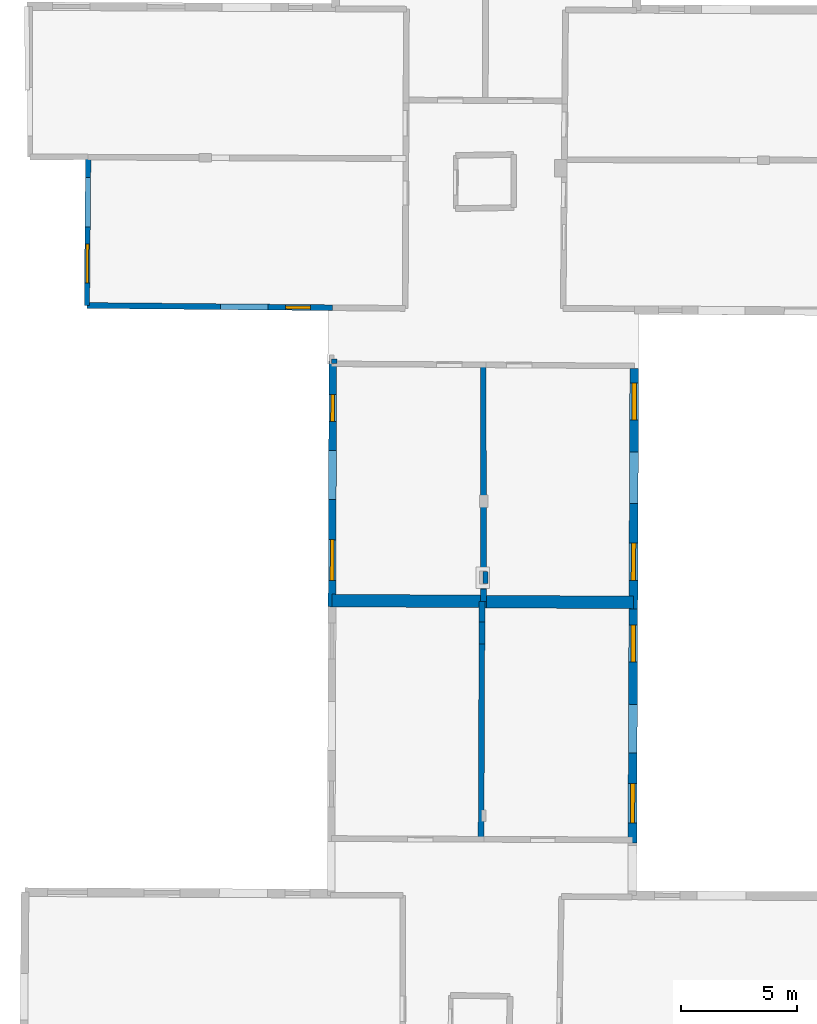
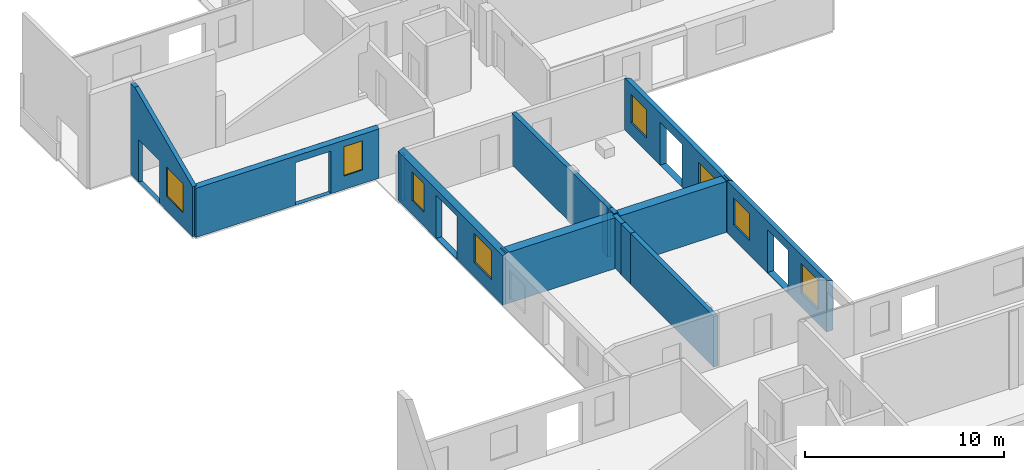
# One storey, part 5 of 10: 14 walls, 8 windows, 13 openings.
"""IFC2X3 building model written with IfcOpenShell, lengths in metres."""

from ifc_helpers import new_model, entity, si_unit, converted_unit, derived_unit, direction, frame, frame_2d, origin, origin_2d_with_axis, place, context, subcontext, project, spatial, polyline, rectangle, outline, extrude, clip, halfspace, source, transform, mapped, material, layer, layer_set, layer_usage, type_object, type_shapes, element, fill, save


model = new_model("IFC2X3")

# Units and contexts
model_context = context("Model", 3, precision=1e-05, world=origin(), true_north=direction((0.0, 1.0)))
body_context = subcontext(model_context, "Body", "Model", "MODEL_VIEW")
ifc_project = project(units=[si_unit("LENGTHUNIT", "METRE"), si_unit("AREAUNIT", "SQUARE_METRE"), si_unit("VOLUMEUNIT", "CUBIC_METRE"), converted_unit("PLANEANGLEUNIT", "DEGREE", entity("IfcRatioMeasure", 0.0174532925199433), si_unit("PLANEANGLEUNIT", "RADIAN"), dimensions=[0, 0, 0, 0, 0, 0, 0]), si_unit("MASSUNIT", "GRAM", prefix="KILO"), derived_unit("MASSDENSITYUNIT", [(si_unit("MASSUNIT", "GRAM", prefix="KILO"), 1), (si_unit("LENGTHUNIT", "METRE"), -3)]), derived_unit("MOMENTOFINERTIAUNIT", [(si_unit("LENGTHUNIT", "METRE"), 4)]), si_unit("TIMEUNIT", "SECOND"), si_unit("FREQUENCYUNIT", "HERTZ"), si_unit("THERMODYNAMICTEMPERATUREUNIT", "DEGREE_CELSIUS"), derived_unit("THERMALTRANSMITTANCEUNIT", [(si_unit("MASSUNIT", "GRAM", prefix="KILO"), 1), (si_unit("THERMODYNAMICTEMPERATUREUNIT", "KELVIN"), -1), (si_unit("TIMEUNIT", "SECOND"), -3)]), derived_unit("VOLUMETRICFLOWRATEUNIT", [(si_unit("LENGTHUNIT", "METRE"), 3), (si_unit("TIMEUNIT", "SECOND"), -1)]), si_unit("ELECTRICCURRENTUNIT", "AMPERE"), si_unit("ELECTRICVOLTAGEUNIT", "VOLT"), si_unit("POWERUNIT", "WATT"), si_unit("FORCEUNIT", "NEWTON", prefix="KILO"), si_unit("ILLUMINANCEUNIT", "LUX"), si_unit("LUMINOUSFLUXUNIT", "LUMEN"), si_unit("LUMINOUSINTENSITYUNIT", "CANDELA"), derived_unit("USERDEFINED", [(si_unit("MASSUNIT", "GRAM", prefix="KILO"), -1), (si_unit("LENGTHUNIT", "METRE"), -2), (si_unit("TIMEUNIT", "SECOND"), 3), (si_unit("LUMINOUSFLUXUNIT", "LUMEN"), 1)]), derived_unit("LINEARVELOCITYUNIT", [(si_unit("LENGTHUNIT", "METRE"), 1), (si_unit("TIMEUNIT", "SECOND"), -1)]), si_unit("PRESSUREUNIT", "PASCAL"), derived_unit("USERDEFINED", [(si_unit("LENGTHUNIT", "METRE"), -2), (si_unit("MASSUNIT", "GRAM", prefix="KILO"), 1), (si_unit("TIMEUNIT", "SECOND"), -2)]), derived_unit("LINEARFORCEUNIT", [(si_unit("MASSUNIT", "GRAM", prefix="KILO"), 1), (si_unit("LENGTHUNIT", "METRE"), 1), (si_unit("TIMEUNIT", "SECOND"), -2), (si_unit("LENGTHUNIT", "METRE"), -1)]), derived_unit("PLANARFORCEUNIT", [(si_unit("MASSUNIT", "GRAM", prefix="KILO"), 1), (si_unit("LENGTHUNIT", "METRE"), 1), (si_unit("TIMEUNIT", "SECOND"), -2), (si_unit("LENGTHUNIT", "METRE"), -2)])], contexts=[model_context])

# Site, building, storey
placement = place(None, origin())
site = spatial("IfcSite", under=ifc_project, at=placement, CompositionType="ELEMENT")
building = spatial("IfcBuilding", under=site, at=placement, CompositionType="ELEMENT")
storey_placement = place(placement, frame((0.0, 0.0, 15.2695512771606)))
storey = spatial("IfcBuildingStorey", under=building, at=storey_placement, Name="Level 6", CompositionType="ELEMENT", Elevation=15.2695512771606)

# Wall, openings, window
ifc_material_1 = material(Name="Default wall")
ifc_layer_1 = layer(ifc_material_1, 0.25)
ifc_layer_set_1 = layer_set([ifc_layer_1], Name="wall_thickness_0.2500")
ifc_layer_usage_1 = layer_usage(ifc_layer_set_1, "AXIS2", "POSITIVE", -0.125)
wall_type_1 = type_object("IfcWallType", Name="wall_thickness_0.2500", PredefinedType="STANDARD", material=ifc_layer_set_1)
wall_1_placement = place(storey_placement, frame((-10.7918631542539, 51.3182891872062, 0.0), z_axis=(0.0, 0.0, 1.0), x_axis=(0.999957297563453, -0.00924137704003364, 0.0)))
wall_1 = element("IfcWallStandardCase", 1, at=wall_1_placement, inside=storey, type_object=wall_type_1, material=ifc_layer_usage_1, Name="Wall:131", ObjectType="Wall", context=body_context, shape_type="Clipping", body=[
    clip(extrude(outline(polyline([(10.5928760190605, -0.125), (10.5928760190605, 0.125), (0.0, 0.125), (0.0, -0.125), (10.5928760190605, -0.125)])), origin(), (0.0, 0.0, 1.0), 3.13044834136963), halfspace(frame((-2.02118983756766, 6.47053663149415, 5.82614615592769), z_axis=(-0.000273451159265104, -0.391129659619298, 0.920335544565435), x_axis=(0.999999114826183, 0.00109145221918171, 0.000760972341273259)), False)),
])
opening_1_placement = place(wall_1_placement, frame((5.74937331769566, -0.125, 0.00544929504394531)))
element("IfcOpeningElement", 2, at=opening_1_placement, cuts=wall_1, Name="Opening : 2065 x 2610 : 121", ObjectType="Opening", context=body_context, shape_type="SweptSolid", body=[
    extrude(rectangle(XDim=2.065, YDim=2.61, at=frame_2d((1.305, 1.0325), x_axis=(0.0, 1.0))), frame((0.0, 0.0, 0.0), z_axis=(0.0, 1.0, 0.0), x_axis=(0.0, 0.0, 1.0)), (0.0, 0.0, 1.0), 0.25),
])
opening_2_placement = place(wall_1_placement, frame((8.56937256748075, -0.125, 0.835448265075684)))
opening_2 = element("IfcOpeningElement", 3, at=opening_2_placement, cuts=wall_1, Name="Opening : 1075 x 1795 : 122", ObjectType="Opening", context=body_context, shape_type="SweptSolid", body=[
    extrude(rectangle(XDim=1.075, YDim=1.795, at=frame_2d((0.8975, 0.5375), x_axis=(0.0, 1.0))), frame((0.0, 0.0, 0.0), z_axis=(0.0, 1.0, 0.0), x_axis=(0.0, 0.0, 1.0)), (0.0, 0.0, 1.0), 0.25),
])
ifc_material_2 = material(Name="Window Default")
window_style_1 = type_object("IfcWindowStyle", Name="Window : 1075 x 1795mm", ConstructionType="NOTDEFINED", OperationType="NOTDEFINED", ParameterTakesPrecedence=False, Sizeable=False, material=ifc_material_2)
shared_shape_1 = source(origin(), body_context, "Body", "SweptSolid", [
    extrude(rectangle(XDim=0.125, YDim=1.075, at=origin_2d_with_axis()), frame((0.5375, 0.125, 0.0), z_axis=(0.0, 0.0, 1.0), x_axis=(0.0, 1.0, 0.0)), (0.0, 0.0, 1.0), 1.795),
])
type_shapes(window_style_1, [shared_shape_1])
window_1_placement = place(opening_2_placement, origin())
window_1 = element("IfcWindow", 4, at=window_1_placement, inside=storey, type_object=window_style_1, Name="Window : 1075 x 1795mm : 69", ObjectType="Window : 1075 x 1795mm", OverallHeight=1.795, OverallWidth=1.075, context=body_context, shape_type="MappedRepresentation", body=[
    mapped(shared_shape_1, transform((0.0, 0.0, 0.0), scale=1.0)),
])
fill(opening_2, window_1)

# Walls
wall_2_placement = place(storey_placement, frame((6.31263852791467, 38.554241578399, 0.0), z_axis=(0.0, 0.0, 1.0), x_axis=(-0.00198018533380732, 0.9999980394311, 0.0)))
element("IfcWallStandardCase", 5, at=wall_2_placement, inside=storey, type_object=wall_type_1, material=ifc_layer_usage_1, Name="Wall:135", ObjectType="Wall", context=body_context, shape_type="Clipping", body=[
    clip(extrude(outline(polyline([(0.536271192998185, -0.125), (0.536271192998185, 0.125), (0.0, 0.125), (0.0, -0.125), (0.536271192998185, -0.125)])), origin(), (0.0, 0.0, 1.0), 3.19044971466064), halfspace(frame((38.6694217245031, -6.58047150093401, 3.16730048752112), z_axis=(-0.00267704851674191, -0.390490946460166, 0.920602875372374), x_axis=(-0.668902738376061, 0.685029747602451, 0.288623234499112)), False)),
])
wall_3_placement = place(storey_placement, frame((6.31157661156335, 39.0905117200006, 0.0), z_axis=(0.0, 0.0, 1.0), x_axis=(-0.00198054367142939, 0.999998038721459, 0.0)))
element("IfcWallStandardCase", 6, at=wall_3_placement, inside=storey, type_object=wall_type_1, material=ifc_layer_usage_1, Name="Wall:136", ObjectType="Wall", context=body_context, shape_type="Clipping", body=[
    clip(extrude(outline(polyline([(9.66558063292127, -0.125), (9.66558063292127, 0.125), (0.0, 0.125), (0.0, -0.125), (9.66558063292127, -0.125)])), origin(), (0.0, 0.0, 1.0), 3.19044971466064), halfspace(frame((38.1331481734673, -6.58048516550286, 3.16730048752112), z_axis=(-0.00267718844461334, -0.390490945500852, 0.920602875372374), x_axis=(-0.668902492903606, 0.685029987295894, 0.288623234499112)), False)),
])
wall_4_placement = place(storey_placement, frame((6.24366578217228, 38.5547016510768, 0.0), z_axis=(0.0, 0.0, 1.0), x_axis=(-0.00408089298600891, -0.99999167312155, 0.0)))
element("IfcWallStandardCase", 7, at=wall_4_placement, inside=storey, type_object=wall_type_1, material=ifc_layer_usage_1, Name="Wall:151", ObjectType="Wall", context=body_context, shape_type="Clipping", body=[
    clip(extrude(outline(polyline([(0.877048166110583, -0.125), (0.877048166110583, 0.125), (0.0, 0.125), (0.0, -0.125), (0.877048166110583, -0.125)])), origin(), (0.0, 0.0, 1.0), 3.13044834136963), halfspace(frame((-37.2581581659903, -7.65857692326388, 2.60439273833051), z_axis=(0.000176715012674681, -0.389900733728327, 0.920856876289642), x_axis=(0.00178910517912589, 0.920854275964437, 0.389902810378011)), False)),
])
wall_5_placement = place(storey_placement, frame((6.24008664246281, 37.6776607880397, 0.0), z_axis=(0.0, 0.0, 1.0), x_axis=(-0.00408033523561015, -0.999991675397533, 0.0)))
element("IfcWallStandardCase", 8, at=wall_5_placement, inside=storey, type_object=wall_type_1, material=ifc_layer_usage_1, Name="Wall:152", ObjectType="Wall", context=body_context, shape_type="Clipping", body=[
    clip(extrude(outline(polyline([(0.965866499927304, -0.125), (0.965866499927304, 0.125), (0.0, 0.125), (0.0, -0.125), (0.965866499927304, -0.125)])), origin(), (0.0, 0.0, 1.0), 3.13044834136963), halfspace(frame((-38.1352106037049, -7.65855565315906, 2.60439273833051), z_axis=(0.000176497543574304, -0.38990073382683, 0.920856876289642), x_axis=(0.00178961879024267, 0.920854274966411, 0.38990281037801)), False)),
])
wall_6_placement = place(storey_placement, frame((6.23614558335026, 36.711802328567, 0.0), z_axis=(0.0, 0.0, 1.0), x_axis=(-0.00408045797511642, -0.999991674896703, 0.0)))
element("IfcWallStandardCase", 9, at=wall_6_placement, inside=storey, type_object=wall_type_1, material=ifc_layer_usage_1, Name="Wall:153", ObjectType="Wall", context=body_context, shape_type="Clipping", body=[
    clip(extrude(outline(polyline([(8.40821971853598, -0.125), (8.40821971853598, 0.125), (0.0, 0.125), (0.0, -0.125), (8.40821971853598, -0.125)])), origin(), (0.0, 0.0, 1.0), 3.13044834136963), halfspace(frame((-39.1010761636167, -7.65856045244585, 2.60439273833051), z_axis=(0.000176545400196313, -0.389900733805164, 0.920856876289642), x_axis=(0.00178950576410035, 0.920854275186063, 0.389902810378011)), False)),
])

# Wall, openings, windows
ifc_layer_2 = layer(ifc_material_1, 0.330000013113022)
ifc_layer_set_2 = layer_set([ifc_layer_2], Name="wall_thickness_0.3300")
ifc_layer_usage_2 = layer_usage(ifc_layer_set_2, "AXIS2", "POSITIVE", -0.165000006556511)
wall_type_2 = type_object("IfcWallType", Name="wall_thickness_0.3300", PredefinedType="STANDARD", material=ifc_layer_set_2)
wall_7_placement = place(storey_placement, frame((-0.189888935039893, 48.9134317004756, 0.0), z_axis=(0.0, 0.0, 1.0), x_axis=(-0.00325150151476131, -0.999994713854978, 0.0)))
wall_7 = element("IfcWallStandardCase", 10, at=wall_7_placement, inside=storey, type_object=wall_type_2, material=ifc_layer_usage_2, Name="Wall:182", ObjectType="Wall", context=body_context, shape_type="Clipping", body=[
    clip(extrude(outline(polyline([(10.5857187994416, -0.165000006556511), (10.5857187994416, 0.165000006556511), (0.0, 0.165000006556511), (0.0, -0.165000006556511), (10.5857187994416, -0.165000006556511)])), origin(), (0.0, 0.0, 1.0), 3.19044971466064), halfspace(frame((-26.9267407728403, -1.1604703505064, 2.60439273833051), z_axis=(-0.000146667536787267, -0.389900746188972, 0.920856876289642), x_axis=(0.00255285831366355, 0.920852475358436, 0.389902810378011)), False)),
])
opening_3_placement = place(wall_7_placement, frame((3.8414395264122, -0.165000006556511, 0.00544929504394531)))
element("IfcOpeningElement", 11, at=opening_3_placement, cuts=wall_7, Name="Opening : 2130 x 2655 : 159", ObjectType="Opening", context=body_context, shape_type="SweptSolid", body=[
    extrude(rectangle(XDim=2.13, YDim=2.655, at=frame_2d((1.3275, 1.065), x_axis=(0.0, 1.0))), frame((0.0, 0.0, 0.0), z_axis=(0.0, 1.0, 0.0), x_axis=(0.0, 0.0, 1.0)), (0.0, 0.0, 1.0), 0.330000013113022),
])
opening_4_placement = place(wall_7_placement, frame((7.69643655852711, -0.165000006556511, 0.870450019836426)))
opening_4 = element("IfcOpeningElement", 12, at=opening_4_placement, cuts=wall_7, Name="Opening : 1750 x 1775 : 160", ObjectType="Opening", context=body_context, shape_type="SweptSolid", body=[
    extrude(rectangle(XDim=1.75, YDim=1.775, at=frame_2d((0.8875, 0.875), x_axis=(0.0, 1.0))), frame((0.0, 0.0, 0.0), z_axis=(0.0, 1.0, 0.0), x_axis=(0.0, 0.0, 1.0)), (0.0, 0.0, 1.0), 0.330000013113022),
])
opening_5_placement = place(wall_7_placement, frame((1.42644491834091, -0.165000006556511, 0.86044979095459)))
opening_5 = element("IfcOpeningElement", 13, at=opening_5_placement, cuts=wall_7, Name="Opening : 1170 x 1770 : 161", ObjectType="Opening", context=body_context, shape_type="SweptSolid", body=[
    extrude(rectangle(XDim=1.17, YDim=1.77, at=frame_2d((0.885, 0.585), x_axis=(0.0, 1.0))), frame((0.0, 0.0, 0.0), z_axis=(0.0, 1.0, 0.0), x_axis=(0.0, 0.0, 1.0)), (0.0, 0.0, 1.0), 0.330000013113022),
])
window_style_2 = type_object("IfcWindowStyle", Name="Window : 1750 x 1775mm", ConstructionType="NOTDEFINED", OperationType="NOTDEFINED", ParameterTakesPrecedence=False, Sizeable=False, material=ifc_material_2)
shared_shape_2 = source(origin(), body_context, "Body", "SweptSolid", [
    extrude(rectangle(XDim=0.165000006556511, YDim=1.75, at=origin_2d_with_axis()), frame((0.875, 0.165000006556511, 0.0), z_axis=(0.0, 0.0, 1.0), x_axis=(0.0, 1.0, 0.0)), (0.0, 0.0, 1.0), 1.775),
])
type_shapes(window_style_2, [shared_shape_2])
window_2_placement = place(opening_4_placement, origin())
window_2 = element("IfcWindow", 14, at=window_2_placement, inside=storey, type_object=window_style_2, Name="Window : 1750 x 1775mm : 87", ObjectType="Window : 1750 x 1775mm", OverallHeight=1.775, OverallWidth=1.75, context=body_context, shape_type="MappedRepresentation", body=[
    mapped(shared_shape_2, transform((0.0, 0.0, 0.0), scale=1.0)),
])
fill(opening_4, window_2)
window_style_3 = type_object("IfcWindowStyle", Name="Window : 1170 x 1770mm", ConstructionType="NOTDEFINED", OperationType="NOTDEFINED", ParameterTakesPrecedence=False, Sizeable=False, material=ifc_material_2)
shared_shape_3 = source(origin(), body_context, "Body", "SweptSolid", [
    extrude(rectangle(XDim=0.165000006556511, YDim=1.17, at=origin_2d_with_axis()), frame((0.585, 0.165000006556511, 0.0), z_axis=(0.0, 0.0, 1.0), x_axis=(0.0, 1.0, 0.0)), (0.0, 0.0, 1.0), 1.77),
])
type_shapes(window_style_3, [shared_shape_3])
window_3_placement = place(opening_5_placement, origin())
window_3 = element("IfcWindow", 15, at=window_3_placement, inside=storey, type_object=window_style_3, Name="Window : 1170 x 1770mm : 88", ObjectType="Window : 1170 x 1770mm", OverallHeight=1.77, OverallWidth=1.17, context=body_context, shape_type="MappedRepresentation", body=[
    mapped(shared_shape_3, transform((0.0, 0.0, 0.0), scale=1.0)),
])
fill(opening_5, window_3)

# Walls
ifc_layer_3 = layer(ifc_material_1, 0.2)
ifc_layer_set_3 = layer_set([ifc_layer_3], Name="wall_thickness_0.2000")
ifc_layer_usage_3 = layer_usage(ifc_layer_set_3, "AXIS2", "POSITIVE", -0.1)
wall_type_3 = type_object("IfcWallType", Name="wall_thickness_0.2000", PredefinedType="STANDARD", material=ifc_layer_set_3)
wall_8_placement = place(storey_placement, frame((-0.239136508430576, 48.9138898782776, 0.0), z_axis=(0.0, 0.0, 1.0), x_axis=(0.999956321638028, -0.00934637984166514, 0.0)))
element("IfcWallStandardCase", 16, at=wall_8_placement, inside=storey, type_object=wall_type_3, material=ifc_layer_usage_3, Name="Wall:159", ObjectType="Wall", context=body_context, shape_type="Clipping", body=[
    clip(extrude(outline(polyline([(0.234684547909792, -0.1), (0.234684547909792, 0.1), (0.0, 0.1), (0.0, -0.1), (0.234684547909792, -0.1)])), origin(), (0.0, 0.0, 1.0), 2.80144786834717), halfspace(frame((-1.27531679324172, 26.9191697175549, 2.60439273833051), z_axis=(-0.38989439790886, -0.00222976890532546, 0.920856876289642), x_axis=(0.920850930574104, 0.00305975818253765, 0.389902810378011)), False)),
])
wall_9_placement = place(storey_placement, frame((6.38936056579438, 39.8542914346706, 0.0), z_axis=(0.0, 0.0, 1.0), x_axis=(0.00216104203392475, -0.999997664945938, 0.0)))
element("IfcWallStandardCase", 17, at=wall_9_placement, inside=storey, type_object=wall_type_3, material=ifc_layer_usage_3, Name="Wall:203", ObjectType="Wall", context=body_context, shape_type="Clipping", body=[
    clip(extrude(outline(polyline([(0.515000592202662, -0.1), (0.515000592202662, 0.1), (0.0, 0.1), (0.0, -0.1), (0.515000592202662, -0.1)])), origin(), (0.0, 0.0, 1.0), 3.13044834136963), halfspace(frame((-37.3683499461351, 6.50793371116991, 3.16730048752112), z_axis=(0.00274767152806975, 0.390490455910629, 0.920602875372374), x_axis=(0.668778834951677, -0.68515071219984, 0.288623234499112)), False)),
])

# Wall, openings, windows
ifc_layer_4 = layer(ifc_material_1, 0.379999995231628)
ifc_layer_set_4 = layer_set([ifc_layer_4], Name="wall_thickness_0.3800")
ifc_layer_usage_4 = layer_usage(ifc_layer_set_4, "AXIS2", "POSITIVE", -0.189999997615814)
wall_type_4 = type_object("IfcWallType", Name="wall_thickness_0.3800", PredefinedType="STANDARD", material=ifc_layer_set_4)
wall_10_placement = place(storey_placement, frame((12.8059081019652, 48.5902860163379, 0.0), z_axis=(0.0, 0.0, 1.0), x_axis=(-0.00393639471888674, -0.999992252368296, 0.0)))
wall_10 = element("IfcWallStandardCase", 18, at=wall_10_placement, inside=storey, type_object=wall_type_4, material=ifc_layer_usage_4, Name="Wall:141", ObjectType="Wall", context=body_context, shape_type="Clipping", body=[
    clip(extrude(outline(polyline([(10.3490906484721, -0.189999997615814), (10.3490906484721, 0.189999997615814), (0.0, 0.189999997615814), (0.0, -0.189999997615814), (10.3490906484721, -0.189999997615814)])), origin(), (0.0, 0.0, 1.0), 3.19044971466064), halfspace(frame((-28.6461518747793, -0.10214694870322, 3.16730048752112), z_axis=(0.000366639720296356, 0.390499950616428, 0.920602875372374), x_axis=(0.672944048130993, -0.681060156368248, 0.288623234499112)), False)),
])
opening_6_placement = place(wall_10_placement, frame((3.58036907290505, -0.189999997615814, 0.00544929504394531)))
element("IfcOpeningElement", 19, at=opening_6_placement, cuts=wall_10, Name="Opening : 2235 x 2655 : 129", ObjectType="Opening", context=body_context, shape_type="SweptSolid", body=[
    extrude(rectangle(XDim=2.235, YDim=2.655, at=frame_2d((1.3275, 1.1175), x_axis=(0.0, 1.0))), frame((0.0, 0.0, 0.0), z_axis=(0.0, 1.0, 0.0), x_axis=(0.0, 0.0, 1.0)), (0.0, 0.0, 1.0), 0.379999995231628),
])
opening_7_placement = place(wall_10_placement, frame((7.50497909873924, -0.189999997615814, 0.850449562072754)))
opening_7 = element("IfcOpeningElement", 20, at=opening_7_placement, cuts=wall_10, Name="Opening : 1630 x 1710 : 130", ObjectType="Opening", context=body_context, shape_type="SweptSolid", body=[
    extrude(rectangle(XDim=1.63, YDim=1.71, at=frame_2d((0.855, 0.815), x_axis=(0.0, 1.0))), frame((0.0, 0.0, 0.0), z_axis=(0.0, 1.0, 0.0), x_axis=(0.0, 0.0, 1.0)), (0.0, 0.0, 1.0), 0.379999995231628),
])
opening_8_placement = place(wall_10_placement, frame((0.624981947167531, -0.189999997615814, 0.835448265075684)))
opening_8 = element("IfcOpeningElement", 21, at=opening_8_placement, cuts=wall_10, Name="Opening : 1595 x 1745 : 131", ObjectType="Opening", context=body_context, shape_type="SweptSolid", body=[
    extrude(rectangle(XDim=1.595, YDim=1.745, at=frame_2d((0.8725, 0.7975), x_axis=(0.0, 1.0))), frame((0.0, 0.0, 0.0), z_axis=(0.0, 1.0, 0.0), x_axis=(0.0, 0.0, 1.0)), (0.0, 0.0, 1.0), 0.379999995231628),
])
window_style_4 = type_object("IfcWindowStyle", Name="Window : 1630 x 1710mm", ConstructionType="NOTDEFINED", OperationType="NOTDEFINED", ParameterTakesPrecedence=False, Sizeable=False, material=ifc_material_2)
shared_shape_4 = source(origin(), body_context, "Body", "SweptSolid", [
    extrude(rectangle(XDim=0.189999997615814, YDim=1.63, at=origin_2d_with_axis()), frame((0.815, 0.189999997615814, 0.0), z_axis=(0.0, 0.0, 1.0), x_axis=(0.0, 1.0, 0.0)), (0.0, 0.0, 1.0), 1.71),
])
type_shapes(window_style_4, [shared_shape_4])
window_4_placement = place(opening_7_placement, origin())
window_4 = element("IfcWindow", 22, at=window_4_placement, inside=storey, type_object=window_style_4, Name="Window : 1630 x 1710mm : 74", ObjectType="Window : 1630 x 1710mm", OverallHeight=1.71, OverallWidth=1.63, context=body_context, shape_type="MappedRepresentation", body=[
    mapped(shared_shape_4, transform((0.0, 0.0, 0.0), scale=1.0)),
])
fill(opening_7, window_4)
window_style_5 = type_object("IfcWindowStyle", Name="Window : 1595 x 1745mm", ConstructionType="NOTDEFINED", OperationType="NOTDEFINED", ParameterTakesPrecedence=False, Sizeable=False, material=ifc_material_2)
shared_shape_5 = source(origin(), body_context, "Body", "SweptSolid", [
    extrude(rectangle(XDim=0.189999997615814, YDim=1.595, at=origin_2d_with_axis()), frame((0.7975, 0.189999997615814, 0.0), z_axis=(0.0, 0.0, 1.0), x_axis=(0.0, 1.0, 0.0)), (0.0, 0.0, 1.0), 1.745),
])
type_shapes(window_style_5, [shared_shape_5])
window_5_placement = place(opening_8_placement, origin())
window_5 = element("IfcWindow", 23, at=window_5_placement, inside=storey, type_object=window_style_5, Name="Window : 1595 x 1745mm : 75", ObjectType="Window : 1595 x 1745mm", OverallHeight=1.745, OverallWidth=1.595, context=body_context, shape_type="MappedRepresentation", body=[
    mapped(shared_shape_5, transform((0.0, 0.0, 0.0), scale=1.0)),
])
fill(opening_8, window_5)

wall_11_placement = place(storey_placement, frame((12.7651699961913, 38.2412755488086, 0.0), z_axis=(0.0, 0.0, 1.0), x_axis=(-0.00393640518905978, -0.999992252327081, 0.0)))
wall_11 = element("IfcWallStandardCase", 24, at=wall_11_placement, inside=storey, type_object=wall_type_4, material=ifc_layer_usage_4, Name="Wall:142", ObjectType="Wall", context=body_context, shape_type="Clipping", body=[
    clip(extrude(outline(polyline([(10.0922565362292, -0.189999997615814), (10.0922565362292, 0.189999997615814), (0.0, 0.189999997615814), (0.0, -0.189999997615814), (10.0922565362292, -0.189999997615814)])), origin(), (0.0, 0.0, 1.0), 3.19044971466064), halfspace(frame((-38.9952425221819, -0.102147356993322, 3.16730048752112), z_axis=(0.000366635631662601, 0.390499950620267, 0.920602875372374), x_axis=(0.672944055261866, -0.681060149322352, 0.288623234499112)), False)),
])
opening_9_placement = place(wall_11_placement, frame((4.11753983128788, -0.189999997615814, 0.0244483947753906)))
element("IfcOpeningElement", 25, at=opening_9_placement, cuts=wall_11, Name="Opening : 2095 x 2650 : 132", ObjectType="Opening", context=body_context, shape_type="SweptSolid", body=[
    extrude(rectangle(XDim=2.095, YDim=2.65, at=frame_2d((1.325, 1.0475), x_axis=(0.0, 1.0))), frame((0.0, 0.0, 0.0), z_axis=(0.0, 1.0, 0.0), x_axis=(0.0, 0.0, 1.0)), (0.0, 0.0, 1.0), 0.379999995231628),
])
opening_10_placement = place(wall_11_placement, frame((0.690888984294078, -0.189999997615814, 0.865448951721191)))
opening_10 = element("IfcOpeningElement", 26, at=opening_10_placement, cuts=wall_11, Name="Opening : 1595 x 1680 : 133", ObjectType="Opening", context=body_context, shape_type="SweptSolid", body=[
    extrude(rectangle(XDim=1.595, YDim=1.68, at=frame_2d((0.84, 0.7975), x_axis=(0.0, 1.0))), frame((0.0, 0.0, 0.0), z_axis=(0.0, 1.0, 0.0), x_axis=(0.0, 0.0, 1.0)), (0.0, 0.0, 1.0), 0.379999995231628),
])
opening_11_placement = place(wall_11_placement, frame((7.52754130578347, -0.189999997615814, 0.869448661804199)))
opening_11 = element("IfcOpeningElement", 27, at=opening_11_placement, cuts=wall_11, Name="Opening : 1700 x 1805 : 134", ObjectType="Opening", context=body_context, shape_type="SweptSolid", body=[
    extrude(rectangle(XDim=1.7, YDim=1.805, at=frame_2d((0.9025, 0.85), x_axis=(0.0, 1.0))), frame((0.0, 0.0, 0.0), z_axis=(0.0, 1.0, 0.0), x_axis=(0.0, 0.0, 1.0)), (0.0, 0.0, 1.0), 0.379999995231628),
])
window_style_6 = type_object("IfcWindowStyle", Name="Window : 1595 x 1680mm", ConstructionType="NOTDEFINED", OperationType="NOTDEFINED", ParameterTakesPrecedence=False, Sizeable=False, material=ifc_material_2)
shared_shape_6 = source(origin(), body_context, "Body", "SweptSolid", [
    extrude(rectangle(XDim=0.189999997615814, YDim=1.595, at=origin_2d_with_axis()), frame((0.7975, 0.189999997615814, 0.0), z_axis=(0.0, 0.0, 1.0), x_axis=(0.0, 1.0, 0.0)), (0.0, 0.0, 1.0), 1.68),
])
type_shapes(window_style_6, [shared_shape_6])
window_6_placement = place(opening_10_placement, origin())
window_6 = element("IfcWindow", 28, at=window_6_placement, inside=storey, type_object=window_style_6, Name="Window : 1595 x 1680mm : 76", ObjectType="Window : 1595 x 1680mm", OverallHeight=1.68, OverallWidth=1.595, context=body_context, shape_type="MappedRepresentation", body=[
    mapped(shared_shape_6, transform((0.0, 0.0, 0.0), scale=1.0)),
])
fill(opening_10, window_6)
window_style_7 = type_object("IfcWindowStyle", Name="Window : 1700 x 1805mm", ConstructionType="NOTDEFINED", OperationType="NOTDEFINED", ParameterTakesPrecedence=False, Sizeable=False, material=ifc_material_2)
shared_shape_7 = source(origin(), body_context, "Body", "SweptSolid", [
    extrude(rectangle(XDim=0.189999997615814, YDim=1.7, at=origin_2d_with_axis()), frame((0.85, 0.189999997615814, 0.0), z_axis=(0.0, 0.0, 1.0), x_axis=(0.0, 1.0, 0.0)), (0.0, 0.0, 1.0), 1.805),
])
type_shapes(window_style_7, [shared_shape_7])
window_7_placement = place(opening_11_placement, origin())
window_7 = element("IfcWindow", 29, at=window_7_placement, inside=storey, type_object=window_style_7, Name="Window : 1700 x 1805mm : 77", ObjectType="Window : 1700 x 1805mm", OverallHeight=1.805, OverallWidth=1.7, context=body_context, shape_type="MappedRepresentation", body=[
    mapped(shared_shape_7, transform((0.0, 0.0, 0.0), scale=1.0)),
])
fill(opening_11, window_7)

# Walls
ifc_layer_5 = layer(ifc_material_1, 0.540000021457672)
ifc_layer_set_5 = layer_set([ifc_layer_5], Name="wall_thickness_0.5400")
ifc_layer_usage_5 = layer_usage(ifc_layer_set_5, "AXIS2", "POSITIVE", -0.270000010728836)
wall_type_5 = type_object("IfcWallType", Name="wall_thickness_0.5400", PredefinedType="STANDARD", material=ifc_layer_set_5)
wall_12_placement = place(storey_placement, frame((-0.223431040906847, 38.59776044414, 0.0), z_axis=(0.0, 0.0, 1.0), x_axis=(0.999977835940196, -0.00665789969599149, 0.0)))
element("IfcWallStandardCase", 30, at=wall_12_placement, inside=storey, type_object=wall_type_5, material=ifc_layer_usage_5, Name="Wall:169", ObjectType="Wall", context=body_context, shape_type="Clipping", body=[
    clip(extrude(outline(polyline([(6.66121035690246, -0.270000010728836), (6.66121035690246, 0.270000010728836), (0.0, 0.270000010728836), (0.0, -0.270000010728836), (6.66121035690246, -0.270000010728836)])), origin(), (0.0, 0.0, 1.0), 3.13044834136963), halfspace(frame((-1.28732715327169, 37.2382974184103, 2.60439273833051), z_axis=(-0.389898983630754, -0.00118150488320604, 0.920856876289642), x_axis=(0.920855828795111, 0.000583980648581989, 0.389902810378011)), False)),
])
wall_13_placement = place(storey_placement, frame((6.4376316765309, 38.5534107737298, 0.0), z_axis=(0.0, 0.0, 1.0), x_axis=(0.999977834864852, -0.00665806120441618, 0.0)))
element("IfcWallStandardCase", 31, at=wall_13_placement, inside=storey, type_object=wall_type_5, material=ifc_layer_usage_5, Name="Wall:170", ObjectType="Wall", context=body_context, shape_type="Clipping", body=[
    clip(extrude(outline(polyline([(6.32874116088703, -0.270000010728836), (6.32874116088703, 0.270000010728836), (0.0, 0.270000010728836), (0.0, -0.270000010728836), (6.32874116088703, -0.270000010728836)])), origin(), (0.0, 0.0, 1.0), 3.13044834136963), halfspace(frame((6.12119627848748, 38.7248209086178, 3.16730048752112), z_axis=(0.390499502151924, 0.000696186193643752, 0.920602875372374), x_axis=(-0.679226080567647, -0.674795198548407, 0.288623234499112)), False)),
])

# Wall, openings, window
ifc_layer_6 = layer(ifc_material_1, 0.230000004172325)
ifc_layer_set_6 = layer_set([ifc_layer_6], Name="wall_thickness_0.2300")
ifc_layer_usage_6 = layer_usage(ifc_layer_set_6, "AXIS2", "POSITIVE", -0.115000002086163)
wall_type_6 = type_object("IfcWallType", Name="wall_thickness_0.2300", PredefinedType="STANDARD", material=ifc_layer_set_6)
wall_14_placement = place(storey_placement, frame((-10.7363551159355, 57.7117663729107, 0.0), z_axis=(0.0, 0.0, 1.0), x_axis=(-0.00868159674032263, -0.999962314228911, 0.0)))
wall_14 = element("IfcWallStandardCase", 32, at=wall_14_placement, inside=storey, type_object=wall_type_6, material=ifc_layer_usage_6, Name="Wall:172", ObjectType="Wall", context=body_context, shape_type="Clipping", body=[
    clip(extrude(outline(polyline([(6.39371553095733, -0.115000002086163), (6.39371553095733, 0.115000002086163), (0.0, 0.115000002086163), (0.0, -0.115000002086163), (6.39371553095733, -0.115000002086163)])), origin(), (0.0, 0.0, 1.0), 5.59044933319092), halfspace(frame((-0.0779489442799731, -2.01756765238547, 5.82614615592769), z_axis=(0.391129445254645, -0.000492406578070923, 0.920335544565435), x_axis=(-0.000531649787060051, 0.999999569134707, 0.000760972341273259)), False)),
])
opening_12_placement = place(wall_14_placement, frame((0.869322178213332, -0.115000002086163, 0.00544929504394531)))
element("IfcOpeningElement", 33, at=opening_12_placement, cuts=wall_14, Name="Opening : 2140 x 2610 : 153", ObjectType="Opening", context=body_context, shape_type="SweptSolid", body=[
    extrude(rectangle(XDim=2.14, YDim=2.61, at=frame_2d((1.305, 1.07), x_axis=(0.0, 1.0))), frame((0.0, 0.0, 0.0), z_axis=(0.0, 1.0, 0.0), x_axis=(0.0, 0.0, 1.0)), (0.0, 0.0, 1.0), 0.230000004172325),
])
opening_13_placement = place(wall_14_placement, frame((3.73931864622122, -0.115000002086163, 0.880448341369629)))
opening_13 = element("IfcOpeningElement", 34, at=opening_13_placement, cuts=wall_14, Name="Opening : 1685 x 1795 : 154", ObjectType="Opening", context=body_context, shape_type="SweptSolid", body=[
    extrude(rectangle(XDim=1.685, YDim=1.795, at=frame_2d((0.8975, 0.8425), x_axis=(0.0, 1.0))), frame((0.0, 0.0, 0.0), z_axis=(0.0, 1.0, 0.0), x_axis=(0.0, 0.0, 1.0)), (0.0, 0.0, 1.0), 0.230000004172325),
])
window_style_8 = type_object("IfcWindowStyle", Name="Window : 1685 x 1795mm", ConstructionType="NOTDEFINED", OperationType="NOTDEFINED", ParameterTakesPrecedence=False, Sizeable=False, material=ifc_material_2)
shared_shape_8 = source(origin(), body_context, "Body", "SweptSolid", [
    extrude(rectangle(XDim=0.115000002086163, YDim=1.685, at=origin_2d_with_axis()), frame((0.8425, 0.115000002086163, 0.0), z_axis=(0.0, 0.0, 1.0), x_axis=(0.0, 1.0, 0.0)), (0.0, 0.0, 1.0), 1.795),
])
type_shapes(window_style_8, [shared_shape_8])
window_8_placement = place(opening_13_placement, origin())
window_8 = element("IfcWindow", 35, at=window_8_placement, inside=storey, type_object=window_style_8, Name="Window : 1685 x 1795mm : 84", ObjectType="Window : 1685 x 1795mm", OverallHeight=1.795, OverallWidth=1.685, context=body_context, shape_type="MappedRepresentation", body=[
    mapped(shared_shape_8, transform((0.0, 0.0, 0.0), scale=1.0)),
])
fill(opening_13, window_8)

save(model, "model.ifc")
